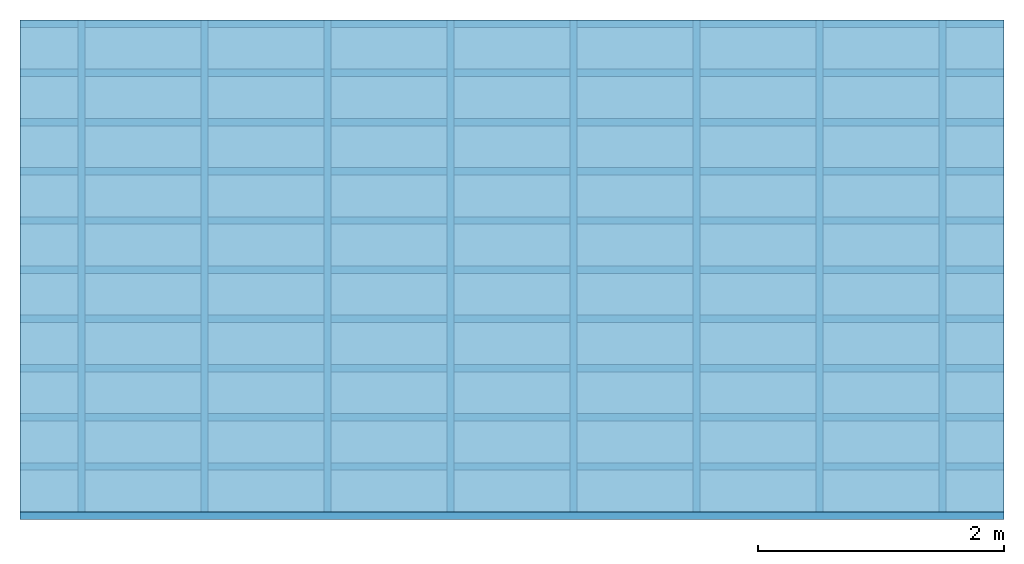
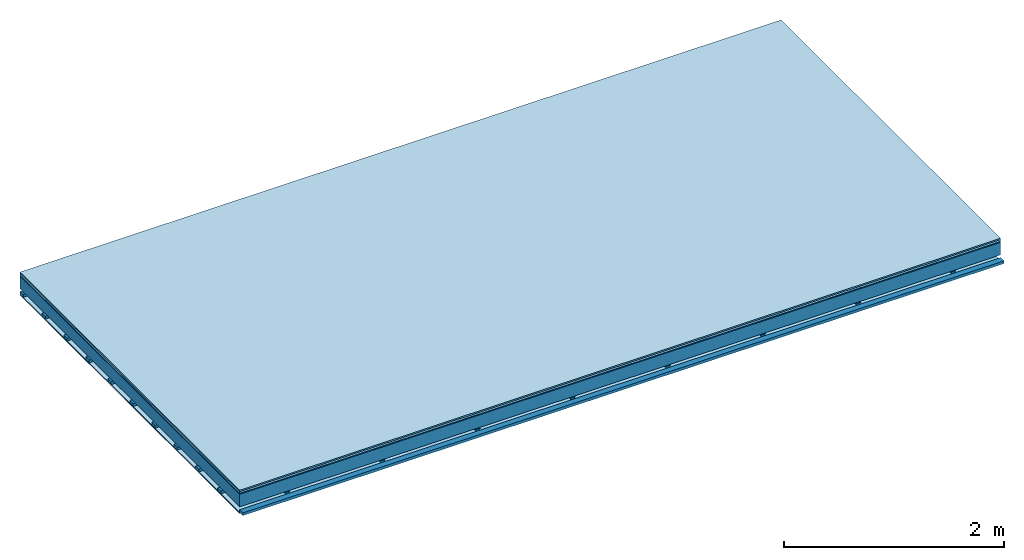
# One storey: 5 plates, 3 members, 1 element without a shape of its own.
"""IFC4 building model written with IfcOpenShell, lengths in metres."""

import ifcopenshell
import ifcopenshell.guid

model = None  # the IFC model being written
_history = None  # IfcOwnerHistory: only IFC2X3 demands one
_inside = {}  # id of a spatial element -> (the spatial element, [elements in it])
_under = {}  # id of a project, library or spatial element -> (it, [spatial elements below it])
_declared = {}  # id of a project -> (the project, [libraries it declares])
_typed = {}  # id of a type object -> (the type object, [elements of that type])
_made_of = {}  # id of a material, layer set ... -> (it, [elements and type objects made of it])


def new_model(schema):
    """Start an empty IFC model of exactly this schema.

    Asked for "IFC4X3", IfcOpenShell would pick the latest addendum, in which some entities
    have other attributes; the version numbers below select the first issue.
    IFC2X3 requires an IfcOwnerHistory on every rooted entity: one is made here for all.
    """
    global model, _history
    if schema == "IFC4X3":
        model = ifcopenshell.file(schema_version=(4, 3, 0, 0))
    else:
        model = ifcopenshell.file(schema=schema)
    _inside.clear()
    _under.clear()
    _declared.clear()
    _typed.clear()
    _made_of.clear()
    _history = None
    if model.schema == "IFC2X3":
        org = make("IfcOrganization", Name="unknown")
        user = make(
            "IfcPersonAndOrganization",
            ThePerson=make("IfcPerson", FamilyName="unknown"),
            TheOrganization=org,
        )
        app = make(
            "IfcApplication",
            ApplicationDeveloper=org,
            Version="unknown",
            ApplicationFullName="unknown",
            ApplicationIdentifier="unknown",
        )
        _history = make(
            "IfcOwnerHistory",
            OwningUser=user,
            OwningApplication=app,
            ChangeAction="ADDED",
            CreationDate=0,
        )
    return model


def make(cls, **values):
    """One entity of the class cls with the attributes given. An attribute that is None is left unset."""
    return model.create_entity(
        cls, **{name: value for name, value in values.items() if value is not None}
    )


def rooted(cls, **values):
    """An entity with a GlobalId (a new one), such as an element, a storey or a relation."""
    return make(cls, GlobalId=ifcopenshell.guid.new(), OwnerHistory=_history, **values)


def si_unit(unit_type, name, prefix=None):
    """IfcSIUnit, for example si_unit("LENGTHUNIT", "METRE", prefix="MILLI")."""
    return make("IfcSIUnit", UnitType=unit_type, Prefix=prefix, Name=name)


def derived_unit(unit_type, elements):
    """IfcDerivedUnit: a product of units, each with its exponent."""
    return make(
        "IfcDerivedUnit",
        Elements=[
            make("IfcDerivedUnitElement", Unit=unit, Exponent=power)
            for unit, power in elements
        ],
        UnitType=unit_type,
    )


def assignment(units):
    """IfcUnitAssignment: the units of a project."""
    return None if units is None else make("IfcUnitAssignment", Units=units)


def point(xyz):
    """IfcCartesianPoint."""
    return None if xyz is None else make("IfcCartesianPoint", Coordinates=xyz)


def direction(xyz):
    """IfcDirection."""
    return None if xyz is None else make("IfcDirection", DirectionRatios=xyz)


def frame(location, z_axis=None, x_axis=None):
    """IfcAxis2Placement3D, a coordinate frame: its origin and axes. An axis left out is left unset."""
    return make(
        "IfcAxis2Placement3D",
        Location=point(location),
        Axis=direction(z_axis),
        RefDirection=direction(x_axis),
    )


def frame_2d(location, x_axis=None):
    """IfcAxis2Placement2D, a coordinate frame in the plane: its origin and x axis."""
    return make(
        "IfcAxis2Placement2D", Location=point(location), RefDirection=direction(x_axis)
    )


def origin():
    """The frame at (0, 0, 0) with its axes left unset."""
    return frame((0.0, 0.0, 0.0))


def origin_with_axes():
    """The frame at (0, 0, 0) with the z axis (0, 0, 1) and the x axis (1, 0, 0) written out."""
    return frame((0.0, 0.0, 0.0), z_axis=(0.0, 0.0, 1.0), x_axis=(1.0, 0.0, 0.0))


def place(relative_to, where):
    """IfcLocalPlacement: puts the frame where relative to a parent placement (None: the world)."""
    return make(
        "IfcLocalPlacement", PlacementRelTo=relative_to, RelativePlacement=where
    )


def context(
    kind, dimensions, precision=None, world=None, true_north=None, identifier=None
):
    """IfcGeometricRepresentationContext, for example the 3D "Model" context."""
    return make(
        "IfcGeometricRepresentationContext",
        ContextIdentifier=identifier,
        ContextType=kind,
        CoordinateSpaceDimension=dimensions,
        Precision=precision,
        WorldCoordinateSystem=world,
        TrueNorth=true_north,
    )


def project(units=None, contexts=None):
    """IfcProject with its units and contexts."""
    return rooted(
        "IfcProject",
        Name="project",
        RepresentationContexts=contexts,
        UnitsInContext=assignment(units),
    )


def spatial(cls, under=None, at=None, **own):
    """A site, building, storey or space (cls), placed at a placement, below another one or the project."""
    s = rooted(cls, ObjectPlacement=at, **own)
    if under is not None:
        _under.setdefault(under.id(), (under, []))[1].append(s)
    return s


def polyline(points):
    """IfcPolyline through the points."""
    return make("IfcPolyline", Points=[point(p) for p in points])


def profile(cls, at=None, kind="AREA", **sizes):
    """A parametric profile (cls). Its sizes go by their IFC names, for example OverallWidth=200.0."""
    return make(cls, ProfileType=kind, Position=at, **sizes)


def rectangle(**sizes):
    """IfcRectangleProfileDef."""
    return profile("IfcRectangleProfileDef", **sizes)


def outline(outer, holes=None, kind="AREA"):
    """IfcArbitraryClosedProfileDef: a profile drawn as a closed curve; with holes, ...WithVoids."""
    if holes is None:
        return make("IfcArbitraryClosedProfileDef", ProfileType=kind, OuterCurve=outer)
    return make(
        "IfcArbitraryProfileDefWithVoids",
        ProfileType=kind,
        OuterCurve=outer,
        InnerCurves=holes,
    )


def extrude(swept, where, along, depth):
    """IfcExtrudedAreaSolid: the profile swept, set in the frame where, extruded along a direction by depth."""
    return make(
        "IfcExtrudedAreaSolid",
        SweptArea=swept,
        Position=where,
        ExtrudedDirection=direction(along),
        Depth=depth,
    )


def shape(context_of_items, identifier, shape_type, items):
    """IfcShapeRepresentation: the items that make up one representation, for example the "Body"."""
    return make(
        "IfcShapeRepresentation",
        ContextOfItems=context_of_items,
        RepresentationIdentifier=identifier,
        RepresentationType=shape_type,
        Items=items,
    )


def material(Name=None, Category=None):
    """IfcMaterial."""
    return make("IfcMaterial", Name=Name, Category=Category)


def layer(
    of_material, thickness, ventilated=None, Name=None, Category=None, Priority=None
):
    """IfcMaterialLayer: one layer of a wall or slab, of a material (None: an air gap)."""
    return make(
        "IfcMaterialLayer",
        Material=of_material,
        LayerThickness=thickness,
        IsVentilated=ventilated,
        Name=Name,
        Category=Category,
        Priority=Priority,
    )


def layer_set(layers, Name=None):
    """IfcMaterialLayerSet."""
    return make("IfcMaterialLayerSet", MaterialLayers=layers, LayerSetName=Name)


def made_of(thing, what):
    """Note that an element or type object is made of a material, layer set ...; save() writes the relation."""
    if what is not None:
        _made_of.setdefault(what.id(), (what, []))[1].append(thing)
    return thing


def type_object(cls, material=None, **own):
    """A type object (cls), such as IfcWallType, which elements share."""
    return made_of(rooted(cls, **own), material)


def element(
    cls,
    number,
    at=None,
    inside=None,
    cuts=None,
    type_object=None,
    material=None,
    context=None,
    identifier="Body",
    shape_type=None,
    held_by="IfcProductDefinitionShape",
    body=None,
    shapes=None,
    **own,
):
    """One element of the class cls, such as IfcWall. Its Tag is "e" and its number.

    at: its placement. inside: the storey or other place that contains it. cuts: it is an
    opening in that element (IfcRelVoidsElement). A single representation is given by context,
    identifier, shape_type and body (its items); several are given by shapes. held_by: the class
    of the entity that holds the representations. save() writes the other relations.
    """
    e = rooted(cls, Tag="e%d" % number, ObjectPlacement=at, **own)
    if body is not None:
        shapes = [shape(context, identifier, shape_type, body)]
    if shapes is not None:
        e.Representation = make(held_by, Representations=shapes)
    if inside is not None:
        _inside.setdefault(inside.id(), (inside, []))[1].append(e)
    if cuts is not None:
        rooted(
            "IfcRelVoidsElement", RelatingBuildingElement=cuts, RelatedOpeningElement=e
        )
    if type_object is not None:
        _typed.setdefault(type_object.id(), (type_object, []))[1].append(e)
    return made_of(e, material)


def aggregate(whole, parts):
    """IfcRelAggregates: a whole, such as a stair, and the parts it consists of."""
    return rooted("IfcRelAggregates", RelatingObject=whole, RelatedObjects=parts)


def save(model, path):
    """Write the relations noted so far, then the file.

    IfcRelAggregates (storeys below a building ...), IfcRelContainedInSpatialStructure (elements
    in a storey), IfcRelDefinesByType, IfcRelAssociatesMaterial and IfcRelDeclares: one each for
    every whole, place, type object, material and project.
    """
    for whole, parts in _under.values():
        aggregate(whole, parts)
    for where, things in _inside.values():
        rooted(
            "IfcRelContainedInSpatialStructure",
            RelatedElements=things,
            RelatingStructure=where,
        )
    for kind, things in _typed.values():
        rooted("IfcRelDefinesByType", RelatedObjects=things, RelatingType=kind)
    for what, things in _made_of.values():
        rooted("IfcRelAssociatesMaterial", RelatedObjects=things, RelatingMaterial=what)
    for by, libraries in _declared.values():
        rooted("IfcRelDeclares", RelatingContext=by, RelatedDefinitions=libraries)
    model.write(path)


model = new_model("IFC4")

# Units and contexts
plan_context = context("Plan", 3, precision=1e-05, world=origin(), true_north=direction((0.0, 1.0)))
model_context = context("Model", 3, precision=1e-05, world=origin(), true_north=direction((0.0, 1.0)))
ifc_project = project(units=[si_unit("LENGTHUNIT", "METRE"), derived_unit("SOUNDPRESSUREUNIT", [(si_unit("PRESSUREUNIT", "PASCAL", prefix="MICRO"), 0)]), si_unit("ENERGYUNIT", "JOULE", prefix="MEGA"), si_unit("MASSUNIT", "GRAM", prefix="KILO"), derived_unit("THERMALTRANSMITTANCEUNIT", [(si_unit("POWERUNIT", "WATT"), 1), (si_unit("AREAUNIT", "SQUARE_METRE"), -1), (si_unit("THERMODYNAMICTEMPERATUREUNIT", "KELVIN"), -1)]), derived_unit("AREADENSITYUNIT", [(si_unit("MASSUNIT", "GRAM", prefix="KILO"), 1), (si_unit("AREAUNIT", "SQUARE_METRE"), -1)]), derived_unit("USERDEFINED", [(si_unit("ENERGYUNIT", "JOULE", prefix="MEGA"), 1), (si_unit("AREAUNIT", "SQUARE_METRE"), -1)])], contexts=[plan_context, model_context])

# Site, building, storey
site = spatial("IfcSite", under=ifc_project)
building_placement = place(None, origin())
building = spatial("IfcBuilding", under=site, at=building_placement)
storey_placement = place(building_placement, origin())
storey = spatial("IfcBuildingStorey", under=building, at=storey_placement)

# Slab, members, plates
ifc_material_1 = material(Category="11.013")
ifc_layer_1 = layer(ifc_material_1, 0.015, Name="Flooring")
ifc_material_2 = material(Category="03.007")
ifc_layer_2 = layer(ifc_material_2, 0.02, Name="On-material")
ifc_material_3 = material(Name="Wood fiber generic product", Category="10.009")
ifc_layer_3 = layer(ifc_material_3, 0.01, Name="Impact sound insulation")
ifc_material_4 = material(Name="no composite action")
ifc_layer_4 = layer(ifc_material_4, 0.0, Name="Bond")
ifc_layer_5 = layer(None, 0.14, Name="Supporting structure")
ifc_layer_6 = layer(ifc_material_4, 0.0, Name="Bond")
ifc_layer_7 = layer(None, 0.03, Name="Coupling")
ifc_layer_8 = layer(None, 0.03, Name="Battens / profiles")
ifc_material_5 = material(Name="Plasterboard type A", Category="03.008")
ifc_layer_9 = layer(ifc_material_5, 0.0125, Name="Ceiling covering 1st layer")
ifc_material_6 = material(Category="04.001")
ifc_layer_10 = layer(ifc_material_6, 0.003, Name="Surface / treatment")
ifc_layer_set = layer_set([ifc_layer_1, ifc_layer_2, ifc_layer_3, ifc_layer_4, ifc_layer_5, ifc_layer_6, ifc_layer_7, ifc_layer_8, ifc_layer_9, ifc_layer_10])
slab_type = type_object("IfcSlabType", Name="A2097", PredefinedType="NOTDEFINED", material=ifc_layer_set)
slab_placement = place(None, frame((0.0, 0.0, 0.0), z_axis=(0.0, 0.0, -1.0), x_axis=(1.0, 0.0, 0.0)))
slab = element("IfcSlab", 1, at=slab_placement, inside=storey, type_object=slab_type, material=ifc_layer_set, Name="Slab #1")
ifc_material_7 = material(Name="Solid timber panel")
member_1_placement = place(slab_placement, origin())
member_1 = element("IfcMember", 2, at=member_1_placement, material=ifc_material_7, Name="Supporting structure", context=plan_context, shape_type="SweptSolid", body=[
    extrude(rectangle(XDim=1.0, YDim=0.14, at=frame_2d((0.5, 0.07), x_axis=(1.0, 0.0))), frame((0.0, 4.0, 0.045), z_axis=(0.0, -1.0, 0.0), x_axis=(1.0, 0.0, 0.0)), (0.0, 0.0, 1.0), 4.0),
    extrude(rectangle(XDim=1.0, YDim=0.14, at=frame_2d((0.5, 0.07), x_axis=(1.0, 0.0))), frame((1.0, 4.0, 0.045), z_axis=(0.0, -1.0, 0.0), x_axis=(1.0, 0.0, 0.0)), (0.0, 0.0, 1.0), 4.0),
    extrude(rectangle(XDim=1.0, YDim=0.14, at=frame_2d((0.5, 0.07), x_axis=(1.0, 0.0))), frame((2.0, 4.0, 0.045), z_axis=(0.0, -1.0, 0.0), x_axis=(1.0, 0.0, 0.0)), (0.0, 0.0, 1.0), 4.0),
    extrude(rectangle(XDim=1.0, YDim=0.14, at=frame_2d((0.5, 0.07), x_axis=(1.0, 0.0))), frame((3.0, 4.0, 0.045), z_axis=(0.0, -1.0, 0.0), x_axis=(1.0, 0.0, 0.0)), (0.0, 0.0, 1.0), 4.0),
    extrude(rectangle(XDim=1.0, YDim=0.14, at=frame_2d((0.5, 0.07), x_axis=(1.0, 0.0))), frame((4.0, 4.0, 0.045), z_axis=(0.0, -1.0, 0.0), x_axis=(1.0, 0.0, 0.0)), (0.0, 0.0, 1.0), 4.0),
    extrude(rectangle(XDim=1.0, YDim=0.14, at=frame_2d((0.5, 0.07), x_axis=(1.0, 0.0))), frame((5.0, 4.0, 0.045), z_axis=(0.0, -1.0, 0.0), x_axis=(1.0, 0.0, 0.0)), (0.0, 0.0, 1.0), 4.0),
    extrude(rectangle(XDim=1.0, YDim=0.14, at=frame_2d((0.5, 0.07), x_axis=(1.0, 0.0))), frame((6.0, 4.0, 0.045), z_axis=(0.0, -1.0, 0.0), x_axis=(1.0, 0.0, 0.0)), (0.0, 0.0, 1.0), 4.0),
    extrude(rectangle(XDim=1.0, YDim=0.14, at=frame_2d((0.5, 0.07), x_axis=(1.0, 0.0))), frame((7.0, 4.0, 0.045), z_axis=(0.0, -1.0, 0.0), x_axis=(1.0, 0.0, 0.0)), (0.0, 0.0, 1.0), 4.0),
])
ifc_material_8 = material()
member_2_placement = place(slab_placement, origin())
member_2 = element("IfcMember", 3, at=member_2_placement, material=ifc_material_8, Name="Coupling", context=plan_context, shape_type="SweptSolid", body=[
    extrude(outline(polyline([(0.0, 0.0), (0.06, 0.0), (0.04, 0.02), (0.02, 0.02), (0.0, 0.0)])), frame((0.47, 4.0, 0.195), z_axis=(0.0, -1.0, 0.0), x_axis=(1.0, 0.0, 0.0)), (0.0, 0.0, 1.0), 4.0),
    extrude(outline(polyline([(0.0, 0.0), (0.06, 0.0), (0.04, 0.02), (0.02, 0.02), (0.0, 0.0)])), frame((1.47, 4.0, 0.195), z_axis=(0.0, -1.0, 0.0), x_axis=(1.0, 0.0, 0.0)), (0.0, 0.0, 1.0), 4.0),
    extrude(outline(polyline([(0.0, 0.0), (0.06, 0.0), (0.04, 0.02), (0.02, 0.02), (0.0, 0.0)])), frame((2.47, 4.0, 0.195), z_axis=(0.0, -1.0, 0.0), x_axis=(1.0, 0.0, 0.0)), (0.0, 0.0, 1.0), 4.0),
    extrude(outline(polyline([(0.0, 0.0), (0.06, 0.0), (0.04, 0.02), (0.02, 0.02), (0.0, 0.0)])), frame((3.47, 4.0, 0.195), z_axis=(0.0, -1.0, 0.0), x_axis=(1.0, 0.0, 0.0)), (0.0, 0.0, 1.0), 4.0),
    extrude(outline(polyline([(0.0, 0.0), (0.06, 0.0), (0.04, 0.02), (0.02, 0.02), (0.0, 0.0)])), frame((4.47, 4.0, 0.195), z_axis=(0.0, -1.0, 0.0), x_axis=(1.0, 0.0, 0.0)), (0.0, 0.0, 1.0), 4.0),
    extrude(outline(polyline([(0.0, 0.0), (0.06, 0.0), (0.04, 0.02), (0.02, 0.02), (0.0, 0.0)])), frame((5.47, 4.0, 0.195), z_axis=(0.0, -1.0, 0.0), x_axis=(1.0, 0.0, 0.0)), (0.0, 0.0, 1.0), 4.0),
    extrude(outline(polyline([(0.0, 0.0), (0.06, 0.0), (0.04, 0.02), (0.02, 0.02), (0.0, 0.0)])), frame((6.47, 4.0, 0.195), z_axis=(0.0, -1.0, 0.0), x_axis=(1.0, 0.0, 0.0)), (0.0, 0.0, 1.0), 4.0),
    extrude(outline(polyline([(0.0, 0.0), (0.06, 0.0), (0.04, 0.02), (0.02, 0.02), (0.0, 0.0)])), frame((7.47, 4.0, 0.195), z_axis=(0.0, -1.0, 0.0), x_axis=(1.0, 0.0, 0.0)), (0.0, 0.0, 1.0), 4.0),
])
member_3_placement = place(slab_placement, origin())
member_3 = element("IfcMember", 4, at=member_3_placement, material=ifc_material_8, Name="Battens / profiles", context=plan_context, shape_type="SweptSolid", body=[
    extrude(rectangle(XDim=0.06, YDim=0.03, at=frame_2d((0.03, 0.015), x_axis=(1.0, 0.0))), frame((0.0, 0.0, 0.215), z_axis=(1.0, 0.0, 0.0), x_axis=(0.0, 1.0, 0.0)), (0.0, 0.0, 1.0), 8.0),
    extrude(rectangle(XDim=0.06, YDim=0.03, at=frame_2d((0.03, 0.015), x_axis=(1.0, 0.0))), frame((0.0, 0.4, 0.215), z_axis=(1.0, 0.0, 0.0), x_axis=(0.0, 1.0, 0.0)), (0.0, 0.0, 1.0), 8.0),
    extrude(rectangle(XDim=0.06, YDim=0.03, at=frame_2d((0.03, 0.015), x_axis=(1.0, 0.0))), frame((0.0, 0.8, 0.215), z_axis=(1.0, 0.0, 0.0), x_axis=(0.0, 1.0, 0.0)), (0.0, 0.0, 1.0), 8.0),
    extrude(rectangle(XDim=0.06, YDim=0.03, at=frame_2d((0.03, 0.015), x_axis=(1.0, 0.0))), frame((0.0, 1.2, 0.215), z_axis=(1.0, 0.0, 0.0), x_axis=(0.0, 1.0, 0.0)), (0.0, 0.0, 1.0), 8.0),
    extrude(rectangle(XDim=0.06, YDim=0.03, at=frame_2d((0.03, 0.015), x_axis=(1.0, 0.0))), frame((0.0, 1.6, 0.215), z_axis=(1.0, 0.0, 0.0), x_axis=(0.0, 1.0, 0.0)), (0.0, 0.0, 1.0), 8.0),
    extrude(rectangle(XDim=0.06, YDim=0.03, at=frame_2d((0.03, 0.015), x_axis=(1.0, 0.0))), frame((0.0, 2.0, 0.215), z_axis=(1.0, 0.0, 0.0), x_axis=(0.0, 1.0, 0.0)), (0.0, 0.0, 1.0), 8.0),
    extrude(rectangle(XDim=0.06, YDim=0.03, at=frame_2d((0.03, 0.015), x_axis=(1.0, 0.0))), frame((0.0, 2.4, 0.215), z_axis=(1.0, 0.0, 0.0), x_axis=(0.0, 1.0, 0.0)), (0.0, 0.0, 1.0), 8.0),
    extrude(rectangle(XDim=0.06, YDim=0.03, at=frame_2d((0.03, 0.015), x_axis=(1.0, 0.0))), frame((0.0, 2.8, 0.215), z_axis=(1.0, 0.0, 0.0), x_axis=(0.0, 1.0, 0.0)), (0.0, 0.0, 1.0), 8.0),
    extrude(rectangle(XDim=0.06, YDim=0.03, at=frame_2d((0.03, 0.015), x_axis=(1.0, 0.0))), frame((0.0, 3.2, 0.215), z_axis=(1.0, 0.0, 0.0), x_axis=(0.0, 1.0, 0.0)), (0.0, 0.0, 1.0), 8.0),
    extrude(rectangle(XDim=0.06, YDim=0.03, at=frame_2d((0.03, 0.015), x_axis=(1.0, 0.0))), frame((0.0, 3.6, 0.215), z_axis=(1.0, 0.0, 0.0), x_axis=(0.0, 1.0, 0.0)), (0.0, 0.0, 1.0), 8.0),
    extrude(rectangle(XDim=0.06, YDim=0.03, at=frame_2d((0.03, 0.015), x_axis=(1.0, 0.0))), frame((0.0, 4.0, 0.215), z_axis=(1.0, 0.0, 0.0), x_axis=(0.0, 1.0, 0.0)), (0.0, 0.0, 1.0), 8.0),
])
plate_1_placement = place(slab_placement, origin())
plate_1 = element("IfcPlate", 5, at=plate_1_placement, material=ifc_material_1, Name="Flooring", context=plan_context, shape_type="SweptSolid", body=[
    extrude(rectangle(XDim=8.0, YDim=4.0, at=frame_2d((4.0, 2.0), x_axis=(1.0, 0.0))), origin_with_axes(), (0.0, 0.0, 1.0), 0.015),
])
plate_2_placement = place(slab_placement, origin())
plate_2 = element("IfcPlate", 6, at=plate_2_placement, material=ifc_material_2, Name="On-material", context=plan_context, shape_type="SweptSolid", body=[
    extrude(rectangle(XDim=8.0, YDim=4.0, at=frame_2d((4.0, 2.0), x_axis=(1.0, 0.0))), frame((0.0, 0.0, 0.015), z_axis=(0.0, 0.0, 1.0), x_axis=(1.0, 0.0, 0.0)), (0.0, 0.0, 1.0), 0.02),
])
plate_3_placement = place(slab_placement, origin())
plate_3 = element("IfcPlate", 7, at=plate_3_placement, material=ifc_material_3, Name="Impact sound insulation", context=plan_context, shape_type="SweptSolid", body=[
    extrude(rectangle(XDim=8.0, YDim=4.0, at=frame_2d((4.0, 2.0), x_axis=(1.0, 0.0))), frame((0.0, 0.0, 0.035), z_axis=(0.0, 0.0, 1.0), x_axis=(1.0, 0.0, 0.0)), (0.0, 0.0, 1.0), 0.01),
])
plate_4_placement = place(slab_placement, origin())
plate_4 = element("IfcPlate", 8, at=plate_4_placement, material=ifc_material_5, Name="Ceiling covering 1st layer", context=plan_context, shape_type="SweptSolid", body=[
    extrude(rectangle(XDim=8.0, YDim=4.0, at=frame_2d((4.0, 2.0), x_axis=(1.0, 0.0))), frame((0.0, 0.0, 0.245), z_axis=(0.0, 0.0, 1.0), x_axis=(1.0, 0.0, 0.0)), (0.0, 0.0, 1.0), 0.0125),
])
plate_5_placement = place(slab_placement, origin())
plate_5 = element("IfcPlate", 9, at=plate_5_placement, material=ifc_material_6, Name="Surface / treatment", context=plan_context, shape_type="SweptSolid", body=[
    extrude(rectangle(XDim=8.0, YDim=4.0, at=frame_2d((4.0, 2.0), x_axis=(1.0, 0.0))), frame((0.0, 0.0, 0.2575), z_axis=(0.0, 0.0, 1.0), x_axis=(1.0, 0.0, 0.0)), (0.0, 0.0, 1.0), 0.003),
])
aggregate(slab, [plate_1, plate_2, plate_3, member_1, member_2, member_3, plate_4, plate_5])

save(model, "model.ifc")
